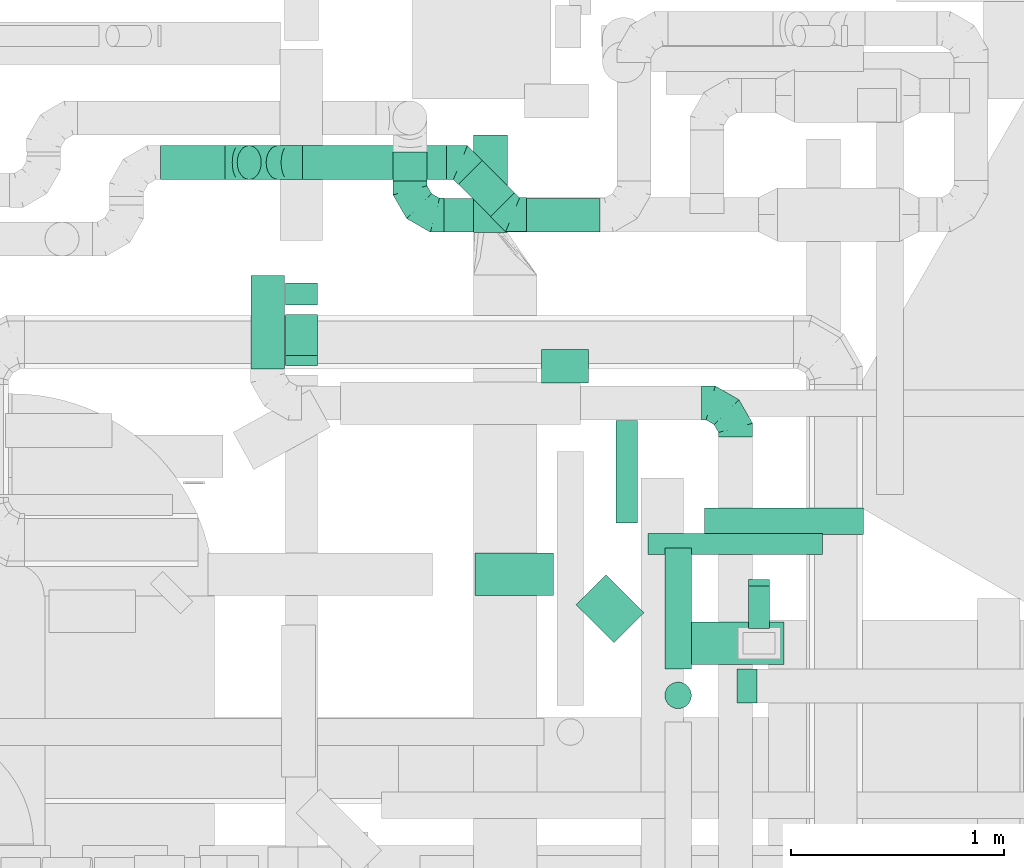
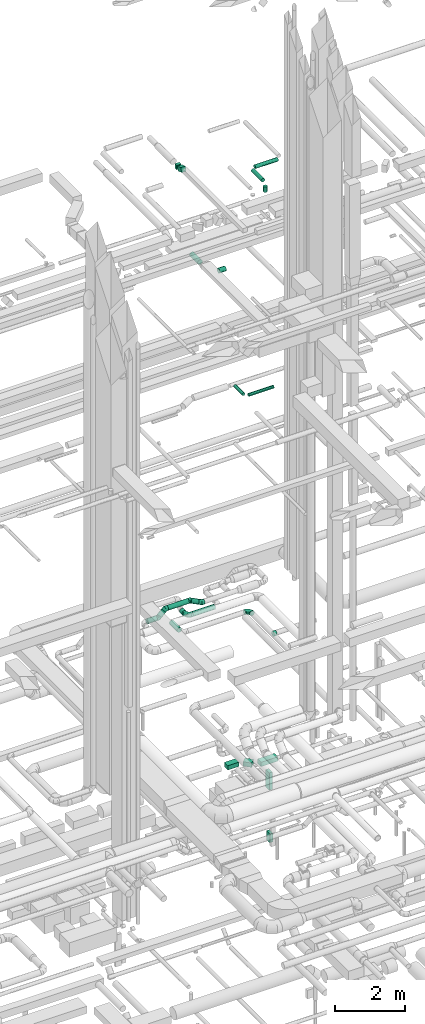
# One storey, part 285 of 337: 21 flow segments, 7 flow fittings.
"""IFC2X3 building model written with IfcOpenShell, lengths in millimetres."""

from ifc_helpers import new_model, entity, si_unit, converted_unit, derived_unit, direction, frame, frame_2d, origin, origin_2d_with_axis, place, context, subcontext, project, spatial, rectangle, circle, extrude, faceted_brep, source, transform, mapped, material, type_object, type_shapes, element, save


model = new_model("IFC2X3")

# Units and contexts
model_context = context("Model", 3, precision=0.01, world=origin(), true_north=direction((6.12303176911189e-17, 1.0)))
body_context = subcontext(model_context, "Body", "Model", "MODEL_VIEW")
ifc_project = project(units=[si_unit("LENGTHUNIT", "METRE", prefix="MILLI"), si_unit("AREAUNIT", "SQUARE_METRE"), si_unit("VOLUMEUNIT", "CUBIC_METRE"), converted_unit("PLANEANGLEUNIT", "DEGREE", entity("IfcRatioMeasure", 0.0174532925199433), si_unit("PLANEANGLEUNIT", "RADIAN"), dimensions=[0, 0, 0, 0, 0, 0, 0]), si_unit("MASSUNIT", "GRAM", prefix="KILO"), derived_unit("MASSDENSITYUNIT", [(si_unit("MASSUNIT", "GRAM", prefix="KILO"), 1), (si_unit("LENGTHUNIT", "METRE"), -3)]), derived_unit("MOMENTOFINERTIAUNIT", [(si_unit("LENGTHUNIT", "METRE"), 4)]), si_unit("TIMEUNIT", "SECOND"), si_unit("FREQUENCYUNIT", "HERTZ"), si_unit("THERMODYNAMICTEMPERATUREUNIT", "DEGREE_CELSIUS"), derived_unit("THERMALTRANSMITTANCEUNIT", [(si_unit("MASSUNIT", "GRAM", prefix="KILO"), 1), (si_unit("THERMODYNAMICTEMPERATUREUNIT", "KELVIN"), -1), (si_unit("TIMEUNIT", "SECOND"), -3)]), derived_unit("VOLUMETRICFLOWRATEUNIT", [(si_unit("LENGTHUNIT", "METRE"), 3), (si_unit("TIMEUNIT", "SECOND"), -1)]), derived_unit("MASSFLOWRATEUNIT", [(si_unit("MASSUNIT", "GRAM", prefix="KILO"), 1), (si_unit("TIMEUNIT", "SECOND"), -1)]), derived_unit("ROTATIONALFREQUENCYUNIT", [(si_unit("TIMEUNIT", "SECOND"), -1)]), si_unit("ELECTRICCURRENTUNIT", "AMPERE"), si_unit("ELECTRICVOLTAGEUNIT", "VOLT"), si_unit("POWERUNIT", "WATT"), si_unit("FORCEUNIT", "NEWTON", prefix="KILO"), si_unit("ILLUMINANCEUNIT", "LUX"), si_unit("LUMINOUSFLUXUNIT", "LUMEN"), si_unit("LUMINOUSINTENSITYUNIT", "CANDELA"), derived_unit("USERDEFINED", [(si_unit("MASSUNIT", "GRAM", prefix="KILO"), -1), (si_unit("LENGTHUNIT", "METRE"), -2), (si_unit("TIMEUNIT", "SECOND"), 3), (si_unit("LUMINOUSFLUXUNIT", "LUMEN"), 1)]), derived_unit("LINEARVELOCITYUNIT", [(si_unit("LENGTHUNIT", "METRE"), 1), (si_unit("TIMEUNIT", "SECOND"), -1)]), si_unit("PRESSUREUNIT", "PASCAL"), derived_unit("USERDEFINED", [(si_unit("LENGTHUNIT", "METRE"), -2), (si_unit("MASSUNIT", "GRAM", prefix="KILO"), 1), (si_unit("TIMEUNIT", "SECOND"), -2)]), derived_unit("LINEARFORCEUNIT", [(si_unit("MASSUNIT", "GRAM", prefix="KILO"), 1), (si_unit("LENGTHUNIT", "METRE"), 1), (si_unit("TIMEUNIT", "SECOND"), -2), (si_unit("LENGTHUNIT", "METRE"), -1)]), derived_unit("PLANARFORCEUNIT", [(si_unit("MASSUNIT", "GRAM", prefix="KILO"), 1), (si_unit("LENGTHUNIT", "METRE"), 1), (si_unit("TIMEUNIT", "SECOND"), -2), (si_unit("LENGTHUNIT", "METRE"), -2)])], contexts=[model_context])

# Site, building, storey
site_placement = place(None, origin())
site = spatial("IfcSite", under=ifc_project, at=site_placement, CompositionType="ELEMENT")
building_placement = place(site_placement, origin())
building = spatial("IfcBuilding", under=site, at=building_placement, CompositionType="ELEMENT")
storey_placement = place(building_placement, origin())
storey = spatial("IfcBuildingStorey", under=building, at=storey_placement, CompositionType="ELEMENT", Elevation=0.0)

# Flow segments
duct_segment_type_1 = type_object("IfcDuctSegmentType", PredefinedType="NOTDEFINED")
flow_segment_1_placement = place(storey_placement, frame((51691.08, 16773.88, -1175.0)))
element("IfcFlowSegment", 1, at=flow_segment_1_placement, inside=storey, type_object=duct_segment_type_1, context=body_context, shape_type="SweptSolid", body=[
    extrude(rectangle(XDim=368.792499999528, YDim=200.0, at=origin_2d_with_axis()), frame((184.4, 100.0, 0.0)), (0.0, 0.0, 1.0), 150.0),
])
flow_segment_2_placement = place(storey_placement, frame((52165.94, 16551.38, -1175.0)))
element("IfcFlowSegment", 2, at=flow_segment_2_placement, inside=storey, type_object=duct_segment_type_1, context=body_context, shape_type="SweptSolid", body=[
    extrude(rectangle(XDim=252.528762761456, YDim=200.000000000004, at=origin_2d_with_axis()), frame((159.99, 159.99, 0.0), z_axis=(0.0, 0.0, 1.0), x_axis=(0.70710678118653, -0.707106781186565, 0.0)), (0.0, 0.0, 1.0), 150.0),
])
flow_segment_3_placement = place(storey_placement, frame((52591.99, 16448.87, -1175.0)))
element("IfcFlowSegment", 3, at=flow_segment_3_placement, inside=storey, type_object=duct_segment_type_1, context=body_context, shape_type="SweptSolid", body=[
    extrude(rectangle(XDim=553.166326049516, YDim=200.0, at=origin_2d_with_axis()), frame((276.58, 100.0, 0.0)), (0.0, 0.0, 1.0), 150.0),
])
flow_segment_4_placement = place(storey_placement, frame((52976.91, 16643.87, -2245.0)))
element("IfcFlowSegment", 4, at=flow_segment_4_placement, inside=storey, type_object=duct_segment_type_1, context=body_context, shape_type="SweptSolid", body=[
    extrude(rectangle(XDim=204.999999999969, YDim=100.000000000003, at=origin_2d_with_axis()), frame((50.0, 102.5, 0.0), z_axis=(0.0, 0.0, 1.0), x_axis=(0.0, 1.0, 0.0)), (0.0, 0.0, 1.0), 600.0),
])
flow_segment_5_placement = place(storey_placement, frame((52976.91, 16618.87, -4050.0)))
element("IfcFlowSegment", 5, at=flow_segment_5_placement, inside=storey, type_object=duct_segment_type_1, context=body_context, shape_type="SweptSolid", body=[
    extrude(rectangle(XDim=200.000024999863, YDim=100.000000000003, at=origin_2d_with_axis()), frame((50.0, 100.0, 0.0), z_axis=(0.0, 0.0, 1.0), x_axis=(0.0, 1.0, 0.0)), (0.0, 0.0, 1.0), 300.0),
])
flow_segment_6_placement = place(storey_placement, frame((50799.92, 17855.43, 19131.13)))
element("IfcFlowSegment", 6, at=flow_segment_6_placement, inside=storey, type_object=duct_segment_type_1, context=body_context, shape_type="SweptSolid", body=[
    extrude(rectangle(XDim=149.999999999999, YDim=150.000000000001, at=frame_2d((0.0, 0.0), x_axis=(0.0, 1.0))), frame((75.0, 22.81, 133.21), z_axis=(0.0, 0.952613829144615, -0.304182334336554), x_axis=(-1.0, 0.0, 0.0)), (0.0, 0.0, 1.0), 203.041489867537),
])
flow_segment_7_placement = place(storey_placement, frame((50799.92, 18140.11, 19116.91)))
element("IfcFlowSegment", 7, at=flow_segment_7_placement, inside=storey, type_object=duct_segment_type_1, context=body_context, shape_type="SweptSolid", body=[
    extrude(rectangle(XDim=103.740397768013, YDim=150.000000000001, at=origin_2d_with_axis()), frame((75.0, 51.87, 0.0), z_axis=(0.0, 0.0, 1.0), x_axis=(0.0, 1.0, 0.0)), (0.0, 0.0, 1.0), 150.000000000001),
])
duct_segment_type_2 = type_object("IfcDuctSegmentType", PredefinedType="NOTDEFINED")
flow_segment_8_placement = place(storey_placement, frame((52353.24, 17115.6, 11348.4)))
element("IfcFlowSegment", 8, at=flow_segment_8_placement, inside=storey, type_object=duct_segment_type_2, context=body_context, shape_type="SweptSolid", body=[
    extrude(circle(Radius=50.0, at=origin_2d_with_axis()), frame((51.6, 0.0, 51.6), z_axis=(0.0, 1.0, 0.0), x_axis=(-1.0, 0.0, 0.0)), (0.0, 0.0, 1.0), 479.999999999999),
])
flow_segment_9_placement = place(storey_placement, frame((52504.84, 16964.01, 11348.4)))
element("IfcFlowSegment", 9, at=flow_segment_9_placement, inside=storey, type_object=duct_segment_type_2, context=body_context, shape_type="SweptSolid", body=[
    extrude(circle(Radius=50.0, at=origin_2d_with_axis()), frame((0.0, 51.6, 51.6), z_axis=(1.0, 0.0, 0.0), x_axis=(0.0, -1.0, 0.0)), (0.0, 0.0, 1.0), 820.000000000004),
])
flow_segment_10_placement = place(storey_placement, frame((52582.47, 16428.82, 19085.9)))
element("IfcFlowSegment", 10, at=flow_segment_10_placement, inside=storey, type_object=duct_segment_type_2, context=body_context, shape_type="SweptSolid", body=[
    extrude(circle(Radius=62.5, at=origin_2d_with_axis()), frame((64.1, 0.0, 64.1), z_axis=(0.0, 1.0, 0.0), x_axis=(1.0, 0.0, 0.0)), (0.0, 0.0, 1.0), 569.000000000033),
])
flow_segment_11_placement = place(storey_placement, frame((52771.56, 17058.73, 19085.9)))
element("IfcFlowSegment", 11, at=flow_segment_11_placement, inside=storey, type_object=duct_segment_type_2, context=body_context, shape_type="SweptSolid", body=[
    extrude(circle(Radius=62.5, at=origin_2d_with_axis()), frame((0.0, 64.1, 64.1), z_axis=(1.0, 0.0, 0.0), x_axis=(0.0, -1.0, 0.0)), (0.0, 0.0, 1.0), 746.250000000112),
])
flow_segment_12_placement = place(storey_placement, frame((51682.37, 18479.95, 15293.4)))
element("IfcFlowSegment", 12, at=flow_segment_12_placement, inside=storey, type_object=duct_segment_type_2, context=body_context, shape_type="SweptSolid", body=[
    extrude(circle(Radius=80.0, at=origin_2d_with_axis()), frame((81.6, 0.0, 81.6), z_axis=(0.0, 1.0, 0.0), x_axis=(-1.0, 0.0, 0.0)), (0.0, 0.0, 1.0), 460.000000000015),
])
flow_segment_13_placement = place(storey_placement, frame((52003.97, 17770.02, 15293.4)))
element("IfcFlowSegment", 13, at=flow_segment_13_placement, inside=storey, type_object=duct_segment_type_2, context=body_context, shape_type="SweptSolid", body=[
    extrude(circle(Radius=80.0, at=origin_2d_with_axis()), frame((0.0, 81.6, 81.6), z_axis=(1.0, 0.0, 0.0), x_axis=(0.0, -1.0, 0.0)), (0.0, 0.0, 1.0), 219.999999999967),
])
flow_segment_14_placement = place(storey_placement, frame((52582.47, 16239.73, 18845.0)))
element("IfcFlowSegment", 14, at=flow_segment_14_placement, inside=storey, type_object=duct_segment_type_2, context=body_context, shape_type="SweptSolid", body=[
    extrude(circle(Radius=62.5, at=origin_2d_with_axis()), frame((64.1, 64.1, 0.0), z_axis=(0.0, 0.0, 1.0), x_axis=(-1.0, 0.0, 0.0)), (0.0, 0.0, 1.0), 180.000000000052),
])
flow_segment_15_placement = place(storey_placement, frame((51545.84, 18480.02, 3118.4)))
element("IfcFlowSegment", 15, at=flow_segment_15_placement, inside=storey, type_object=duct_segment_type_2, context=body_context, shape_type="SweptSolid", body=[
    extrude(circle(Radius=80.0, at=origin_2d_with_axis()), frame((0.0, 81.6, 81.6), z_axis=(1.0, 0.0, 0.0), x_axis=(0.0, -1.0, 0.0)), (0.0, 0.0, 1.0), 732.500000000007),
])
flow_segment_16_placement = place(storey_placement, frame((51304.24, 18721.61, 3118.4)))
element("IfcFlowSegment", 16, at=flow_segment_16_placement, inside=storey, type_object=duct_segment_type_2, context=body_context, shape_type="SweptSolid", body=[
    extrude(circle(Radius=80.0, at=origin_2d_with_axis()), frame((81.6, 0.0, 81.6), z_axis=(0.0, 1.0, 0.0), x_axis=(1.0, 0.0, 0.0)), (0.0, 0.0, 1.0), 137.500000000034),
])
flow_segment_17_placement = place(storey_placement, frame((51611.62, 18552.81, 3418.4)))
element("IfcFlowSegment", 17, at=flow_segment_17_placement, inside=storey, type_object=duct_segment_type_2, context=body_context, shape_type="SweptSolid", body=[
    extrude(circle(Radius=80.0, at=origin_2d_with_axis()), frame((209.85, 58.16, 81.6), z_axis=(-0.707106781186477, 0.707106781186618, 0.0), x_axis=(0.707106781186618, 0.707106781186477, 0.0)), (0.0, 0.0, 1.0), 214.52272785248),
])
flow_segment_18_placement = place(storey_placement, frame((50212.92, 18727.93, 3188.4)))
element("IfcFlowSegment", 18, at=flow_segment_18_placement, inside=storey, type_object=duct_segment_type_2, context=body_context, shape_type="SweptSolid", body=[
    extrude(circle(Radius=80.0, at=origin_2d_with_axis()), frame((0.0, 81.6, 81.6), z_axis=(1.0, 0.0, 0.0), x_axis=(0.0, 1.0, 0.0)), (0.0, 0.0, 1.0), 303.725830020343),
])
flow_segment_19_placement = place(storey_placement, frame((50879.19, 18727.93, 3418.4)))
element("IfcFlowSegment", 19, at=flow_segment_19_placement, inside=storey, type_object=duct_segment_type_2, context=body_context, shape_type="SweptSolid", body=[
    extrude(circle(Radius=80.0, at=origin_2d_with_axis()), frame((0.0, 81.6, 81.6), z_axis=(1.0, 0.0, 0.0), x_axis=(0.0, 1.0, 0.0)), (0.0, 0.0, 1.0), 677.451660040652),
])
flow_segment_20_placement = place(storey_placement, frame((50571.62, 18727.93, 3258.7)))
element("IfcFlowSegment", 20, at=flow_segment_20_placement, inside=storey, type_object=duct_segment_type_2, context=body_context, shape_type="SweptSolid", body=[
    extrude(circle(Radius=80.0, at=origin_2d_with_axis()), frame((58.16, 81.6, 58.16), z_axis=(0.707106781186543, 0.0, 0.707106781186552), x_axis=(0.0, 1.0, 0.0)), (0.0, 0.0, 1.0), 192.720779386393),
])
flow_segment_21_placement = place(storey_placement, frame((50635.15, 17838.74, 3298.4)))
element("IfcFlowSegment", 21, at=flow_segment_21_placement, inside=storey, type_object=duct_segment_type_2, context=body_context, shape_type="SweptSolid", body=[
    extrude(circle(Radius=80.0, at=origin_2d_with_axis()), frame((81.6, 0.0, 81.6), z_axis=(0.0, 1.0, 0.0), x_axis=(1.0, 0.0, 0.0)), (0.0, 0.0, 1.0), 440.000000000006),
])

# Flow fittings
ifc_material = material()
duct_fitting_type_1 = type_object("IfcDuctFittingType", PredefinedType="NOTDEFINED", material=ifc_material)
shared_shape_1 = source(origin(), body_context, "Body", "Brep", [
    faceted_brep([(-160.0, 0.0, -80.0), (-160.0, -20.71, -77.27), (-160.0, -40.0, -69.28), (-160.0, -56.57, -56.57), (-160.0, -69.28, -40.0), (-160.0, -77.27, -20.71), (-160.0, -80.0, 0.0), (-160.0, -77.27, 20.71), (-160.0, -69.28, 40.0), (-160.0, -56.57, 56.57), (-160.0, -40.0, 69.28), (-160.0, -20.71, 77.27), (-160.0, 0.0, 80.0), (-160.0, 20.71, 77.27), (-160.0, 40.0, 69.28), (-160.0, 56.57, 56.57), (-160.0, 69.28, 40.0), (-160.0, 77.27, 20.71), (-160.0, 80.0, 0.0), (-160.0, 77.27, -20.71), (-160.0, 69.28, -40.0), (-160.0, 56.57, -56.57), (-160.0, 40.0, -69.28), (-160.0, 20.71, -77.27), (-122.68, 20.71, 77.27), (-127.85, 40.0, 69.28), (-117.13, 0.0, 80.0), (-132.29, 56.57, 56.57), (-137.83, 77.27, 20.71), (-138.56, 80.0, 0.0), (-135.69, 69.28, 40.0), (-135.69, 69.28, -40.0), (-132.29, 56.57, -56.57), (-137.83, 77.27, -20.71), (-122.68, 20.71, -77.27), (-117.13, 0.0, -80.0), (-127.85, 40.0, -69.28), (-111.58, -20.71, -77.27), (-106.41, -40.0, -69.28), (-101.97, -56.57, -56.57), (-98.56, -69.28, -40.0), (-96.42, -77.27, -20.71), (-95.69, -80.0, 0.0), (-96.42, -77.27, 20.71), (-98.56, -69.28, 40.0), (-101.97, -56.57, 56.57), (-106.41, -40.0, 69.28), (-111.58, -20.71, 77.27), (-58.03, 58.03, 77.27), (-72.15, 72.15, 69.28), (-42.87, 42.87, 80.0), (-84.28, 84.28, 56.57), (-93.59, 93.59, 40.0), (-99.44, 99.44, 20.71), (-101.44, 101.44, 0.0), (-99.44, 99.44, -20.71), (-93.59, 93.59, -40.0), (-84.28, 84.28, -56.57), (-58.03, 58.03, -77.27), (-42.87, 42.87, -80.0), (-72.15, 72.15, -69.28), (-27.71, 27.71, -77.27), (-13.59, 13.59, -69.28), (-1.46, 1.46, -56.57), (7.85, -7.85, -40.0), (13.7, -13.7, -20.71), (15.69, -15.69, 0.0), (13.7, -13.7, 20.71), (7.85, -7.85, 40.0), (-1.46, 1.46, 56.57), (-13.59, 13.59, 69.28), (-27.71, 27.71, 77.27), (-20.71, 122.68, 77.27), (-40.0, 127.85, 69.28), (0.0, 117.13, 80.0), (-56.57, 132.29, 56.57), (-69.28, 135.69, 40.0), (-77.27, 137.83, 20.71), (-80.0, 138.56, 0.0), (-77.27, 137.83, -20.71), (-69.28, 135.69, -40.0), (-56.57, 132.29, -56.57), (-20.71, 122.68, -77.27), (0.0, 117.13, -80.0), (-40.0, 127.85, -69.28), (20.71, 111.58, -77.27), (40.0, 106.41, -69.28), (56.57, 101.97, -56.57), (69.28, 98.56, -40.0), (77.27, 96.42, -20.71), (80.0, 95.69, 0.0), (77.27, 96.42, 20.71), (69.28, 98.56, 40.0), (56.57, 101.97, 56.57), (40.0, 106.41, 69.28), (20.71, 111.58, 77.27), (-20.71, 160.0, -77.27), (-40.0, 160.0, -69.28), (-56.57, 160.0, -56.57), (-69.28, 160.0, -40.0), (-77.27, 160.0, -20.71), (-80.0, 160.0, 0.0), (-77.27, 160.0, 20.71), (-69.28, 160.0, 40.0), (-56.57, 160.0, 56.57), (-40.0, 160.0, 69.28), (-20.71, 160.0, 77.27), (0.0, 160.0, 80.0), (20.71, 160.0, 77.27), (40.0, 160.0, 69.28), (56.57, 160.0, 56.57), (69.28, 160.0, 40.0), (77.27, 160.0, 20.71), (80.0, 160.0, 0.0), (77.27, 160.0, -20.71), (69.28, 160.0, -40.0), (56.57, 160.0, -56.57), (40.0, 160.0, -69.28), (20.71, 160.0, -77.27), (0.0, 160.0, -80.0)], [[[0, 1, 2, 3, 4, 5, 6, 7, 8, 9, 10, 11, 12, 13, 14, 15, 16, 17, 18, 19, 20, 21, 22, 23]], [[24, 25, 14, 13]], [[26, 24, 13, 12]], [[14, 25, 27, 15]], [[28, 29, 18, 17]], [[30, 28, 17, 16]], [[15, 27, 30, 16]], [[20, 31, 32, 21]], [[33, 31, 20, 19]], [[18, 29, 33, 19]], [[34, 35, 0, 23]], [[36, 34, 23, 22]], [[32, 36, 22, 21]], [[1, 0, 35, 37]], [[2, 1, 37, 38]], [[3, 2, 38, 39]], [[5, 4, 40, 41]], [[6, 5, 41, 42]], [[39, 40, 4, 3]], [[6, 42, 43, 7]], [[7, 43, 44, 8]], [[8, 44, 45, 9]], [[9, 45, 46, 10]], [[10, 46, 47, 11]], [[26, 12, 11, 47]], [[48, 49, 25, 24]], [[50, 48, 24, 26]], [[27, 25, 49, 51]], [[52, 53, 28, 30]], [[51, 52, 30, 27]], [[29, 28, 53, 54]], [[55, 56, 31, 33]], [[54, 55, 33, 29]], [[32, 31, 56, 57]], [[58, 59, 35, 34]], [[60, 58, 34, 36]], [[57, 60, 36, 32]], [[37, 35, 59, 61]], [[38, 37, 61, 62]], [[39, 38, 62, 63]], [[41, 40, 64, 65]], [[42, 41, 65, 66]], [[63, 64, 40, 39]], [[43, 42, 66, 67]], [[44, 43, 67, 68]], [[68, 69, 45, 44]], [[46, 45, 69, 70]], [[47, 46, 70, 71]], [[26, 47, 71, 50]], [[72, 73, 49, 48]], [[74, 72, 48, 50]], [[51, 49, 73, 75]], [[76, 77, 53, 52]], [[75, 76, 52, 51]], [[54, 53, 77, 78]], [[79, 80, 56, 55]], [[78, 79, 55, 54]], [[57, 56, 80, 81]], [[82, 83, 59, 58]], [[84, 82, 58, 60]], [[81, 84, 60, 57]], [[61, 59, 83, 85]], [[62, 61, 85, 86]], [[63, 62, 86, 87]], [[65, 64, 88, 89]], [[66, 65, 89, 90]], [[87, 88, 64, 63]], [[67, 66, 90, 91]], [[68, 67, 91, 92]], [[92, 93, 69, 68]], [[70, 69, 93, 94]], [[71, 70, 94, 95]], [[50, 71, 95, 74]], [[96, 97, 98, 99, 100, 101, 102, 103, 104, 105, 106, 107, 108, 109, 110, 111, 112, 113, 114, 115, 116, 117, 118, 119]], [[72, 74, 107, 106]], [[73, 72, 106, 105]], [[75, 73, 105, 104]], [[77, 76, 103, 102]], [[78, 77, 102, 101]], [[75, 104, 103, 76]], [[78, 101, 100, 79]], [[79, 100, 99, 80]], [[80, 99, 98, 81]], [[84, 97, 96, 82]], [[82, 96, 119, 83]], [[84, 81, 98, 97]], [[118, 117, 86, 85]], [[119, 118, 85, 83]], [[116, 87, 86, 117]], [[88, 115, 114, 89]], [[89, 114, 113, 90]], [[115, 88, 87, 116]], [[112, 111, 92, 91]], [[113, 112, 91, 90]], [[111, 110, 93, 92]], [[95, 94, 109, 108]], [[74, 95, 108, 107]], [[110, 109, 94, 93]]]),
])
type_shapes(duct_fitting_type_1, [shared_shape_1])
for number, where, z_axis, x_axis in (
    (22, (51385.84, 18561.61, 3200.0), (0.0, 0.0, 1.0), (0.0, -1.0, 0.0)),
    (23, (52916.74, 17678.74, 3380.0), (0.0, 0.0, 1.0), (0.0, 1.0, 0.0)),
):
    element("IfcFlowFitting", number, at=place(storey_placement, frame(where, z_axis=z_axis, x_axis=x_axis)), inside=storey, type_object=duct_fitting_type_1, material=ifc_material, context=body_context, shape_type="MappedRepresentation", body=[
        mapped(shared_shape_1, transform((0.0, 0.0, 0.0), scale=1.0)),
    ])
duct_fitting_type_2 = type_object("IfcDuctFittingType", PredefinedType="NOTDEFINED", material=ifc_material)
shared_shape_2 = source(origin(), body_context, "Body", "Brep", [
    faceted_brep([(-66.27, 0.0, -80.0), (-66.27, -20.71, -77.27), (-66.27, -40.0, -69.28), (-66.27, -56.57, -56.57), (-66.27, -69.28, -40.0), (-66.27, -77.27, -20.71), (-66.27, -80.0, 0.0), (-66.27, -77.27, 20.71), (-66.27, -69.28, 40.0), (-66.27, -56.57, 56.57), (-66.27, -40.0, 69.28), (-66.27, -20.71, 77.27), (-66.27, 0.0, 80.0), (-66.27, 20.71, 77.27), (-66.27, 40.0, 69.28), (-66.27, 56.57, 56.57), (-66.27, 69.28, 40.0), (-66.27, 77.27, 20.71), (-66.27, 80.0, 0.0), (-66.27, 77.27, -20.71), (-66.27, 69.28, -40.0), (-66.27, 56.57, -56.57), (-66.27, 40.0, -69.28), (-66.27, 20.71, -77.27), (-8.58, 20.71, 77.27), (-16.57, 40.0, 69.28), (0.0, 0.0, 80.0), (-23.43, 56.57, 56.57), (-28.7, 69.28, 40.0), (-32.01, 77.27, 20.71), (-33.14, 80.0, 0.0), (-32.01, 77.27, -20.71), (-28.7, 69.28, -40.0), (-23.43, 56.57, -56.57), (-8.58, 20.71, -77.27), (0.0, 0.0, -80.0), (-16.57, 40.0, -69.28), (8.58, -20.71, -77.27), (16.57, -40.0, -69.28), (23.43, -56.57, -56.57), (28.7, -69.28, -40.0), (32.01, -77.27, -20.71), (33.14, -80.0, 0.0), (32.01, -77.27, 20.71), (28.7, -69.28, 40.0), (23.43, -56.57, 56.57), (16.57, -40.0, 69.28), (8.58, -20.71, 77.27), (46.86, 46.86, 80.0), (32.22, 61.5, 77.27), (18.58, 75.15, 69.28), (6.86, 86.86, 56.57), (-2.13, 95.85, 40.0), (-7.78, 101.5, 20.71), (-9.71, 103.43, 0.0), (-7.78, 101.5, -20.71), (-2.13, 95.85, -40.0), (6.86, 86.86, -56.57), (18.58, 75.15, -69.28), (32.22, 61.5, -77.27), (46.86, 46.86, -80.0), (61.5, 32.22, -77.27), (75.15, 18.58, -69.28), (86.86, 6.86, -56.57), (95.85, -2.13, -40.0), (101.5, -7.78, -20.71), (103.43, -9.71, 0.0), (101.5, -7.78, 20.71), (95.85, -2.13, 40.0), (86.86, 6.86, 56.57), (75.15, 18.58, 69.28), (61.5, 32.22, 77.27)], [[[0, 1, 2, 3, 4, 5, 6, 7, 8, 9, 10, 11, 12, 13, 14, 15, 16, 17, 18, 19, 20, 21, 22, 23]], [[24, 25, 14, 13]], [[26, 24, 13, 12]], [[14, 25, 27, 15]], [[28, 29, 17, 16]], [[28, 16, 15, 27]], [[30, 18, 17, 29]], [[31, 32, 20, 19]], [[30, 31, 19, 18]], [[32, 33, 21, 20]], [[34, 35, 0, 23]], [[36, 34, 23, 22]], [[33, 36, 22, 21]], [[1, 0, 35, 37]], [[2, 1, 37, 38]], [[38, 39, 3, 2]], [[5, 4, 40, 41]], [[6, 5, 41, 42]], [[39, 40, 4, 3]], [[6, 42, 43, 7]], [[7, 43, 44, 8]], [[8, 44, 45, 9]], [[9, 45, 46, 10]], [[10, 46, 47, 11]], [[26, 12, 11, 47]], [[24, 26, 48, 49]], [[25, 24, 49, 50]], [[27, 25, 50, 51]], [[29, 28, 52, 53]], [[30, 29, 53, 54]], [[51, 52, 28, 27]], [[30, 54, 55, 31]], [[31, 55, 56, 32]], [[57, 33, 32, 56]], [[36, 58, 59, 34]], [[34, 59, 60, 35]], [[58, 36, 33, 57]], [[35, 60, 61, 37]], [[37, 61, 62, 38]], [[63, 39, 38, 62]], [[40, 64, 65, 41]], [[41, 65, 66, 42]], [[64, 40, 39, 63]], [[43, 42, 66, 67]], [[44, 43, 67, 68]], [[68, 69, 45, 44]], [[47, 46, 70, 71]], [[26, 47, 71, 48]], [[69, 70, 46, 45]], [[59, 58, 57, 56, 55, 54, 53, 52, 51, 50, 49, 48, 71, 70, 69, 68, 67, 66, 65, 64, 63, 62, 61, 60]]]),
])
type_shapes(duct_fitting_type_2, [shared_shape_2])
for number, where, z_axis, x_axis in (
    (24, (51868.34, 18564.11, 3500.0), (0.0, 0.0, 1.0), (0.707106781186541, -0.707106781186554, 0.0)),
    (25, (51622.92, 18809.53, 3500.0), (0.0, 0.0, 1.0), (-0.707106781186512, 0.707106781186583, 0.0)),
    (26, (50812.92, 18809.53, 3500.0), (0.0, -1.0, 0.0), (-1.0, 0.0, 0.0)),
    (27, (50582.92, 18809.53, 3270.0), (0.0, 1.0, 0.0), (-0.707106781186481, 0.0, -0.707106781186614)),
):
    element("IfcFlowFitting", number, at=place(storey_placement, frame(where, z_axis=z_axis, x_axis=x_axis)), inside=storey, type_object=duct_fitting_type_2, material=ifc_material, context=body_context, shape_type="MappedRepresentation", body=[
        mapped(shared_shape_2, transform((0.0, 0.0, 0.0), scale=1.0)),
    ])
duct_fitting_type_3 = type_object("IfcDuctFittingType", PredefinedType="NOTDEFINED", material=ifc_material)
shared_shape_3 = source(origin(), body_context, "Body", "Brep", [
    faceted_brep([(20.0, 20.71, -77.27), (20.0, 40.0, -69.28), (20.0, 56.57, -56.57), (20.0, 69.28, -40.0), (20.0, 77.27, -20.71), (20.0, 80.0, 0.0), (20.0, 77.27, 20.71), (20.0, 69.28, 40.0), (20.0, 56.57, 56.57), (20.0, 40.0, 69.28), (20.0, 20.71, 77.27), (20.0, 0.0, 80.0), (20.0, -20.71, 77.27), (20.0, -40.0, 69.28), (20.0, -56.57, 56.57), (20.0, -69.28, 40.0), (20.0, -77.27, 20.71), (20.0, -80.0, 0.0), (20.0, -77.27, -20.71), (20.0, -69.28, -40.0), (20.0, -56.57, -56.57), (20.0, -40.0, -69.28), (20.0, -20.71, -77.27), (20.0, 0.0, -80.0), (0.0, 0.0, 80.0), (0.0, 20.71, 77.27), (-73.9, 20.71, 77.27), (-73.9, 0.0, 80.0), (0.0, 40.0, 69.28), (-73.9, 40.0, 69.28), (0.0, 56.57, 56.57), (-73.9, 56.57, 56.57), (0.0, 69.28, 40.0), (0.0, 77.27, 20.71), (-73.9, 77.27, 20.71), (-73.9, 69.28, 40.0), (0.0, 80.0, 0.0), (-73.9, 80.0, 0.0), (0.0, 77.27, -20.71), (-73.9, 77.27, -20.71), (0.0, 69.28, -40.0), (-73.9, 69.28, -40.0), (0.0, 56.57, -56.57), (-73.9, 56.57, -56.57), (0.0, 40.0, -69.28), (0.0, 20.71, -77.27), (-73.9, 20.71, -77.27), (-73.9, 40.0, -69.28), (0.0, 0.0, -80.0), (-73.9, 0.0, -80.0), (0.0, -20.71, -77.27), (-73.9, -20.71, -77.27), (0.0, -40.0, -69.28), (-73.9, -40.0, -69.28), (0.0, -56.57, -56.57), (-73.9, -56.57, -56.57), (0.0, -69.28, -40.0), (0.0, -77.27, -20.71), (-73.9, -77.27, -20.71), (-73.9, -69.28, -40.0), (0.0, -80.0, 0.0), (-73.9, -80.0, 0.0), (0.0, -77.27, 20.71), (-73.9, -77.27, 20.71), (0.0, -69.28, 40.0), (-73.9, -69.28, 40.0), (0.0, -56.57, 56.57), (-73.9, -56.57, 56.57), (0.0, -40.0, 69.28), (0.0, -20.71, 77.27), (-73.9, -20.71, 77.27), (-73.9, -40.0, 69.28)], [[[0, 1, 2, 3, 4, 5, 6, 7, 8, 9, 10, 11, 12, 13, 14, 15, 16, 17, 18, 19, 20, 21, 22, 23]], [[24, 11, 10, 25, 26, 27]], [[25, 10, 9, 28, 29, 26]], [[28, 9, 8, 30, 31, 29]], [[32, 7, 6, 33, 34, 35]], [[33, 6, 5, 36, 37, 34]], [[30, 8, 7, 32, 35, 31]], [[36, 5, 4, 38, 39, 37]], [[38, 4, 3, 40, 41, 39]], [[40, 3, 2, 42, 43, 41]], [[44, 1, 0, 45, 46, 47]], [[45, 0, 23, 48, 49, 46]], [[42, 2, 1, 44, 47, 43]], [[48, 23, 22, 50, 51, 49]], [[50, 22, 21, 52, 53, 51]], [[52, 21, 20, 54, 55, 53]], [[56, 19, 18, 57, 58, 59]], [[57, 18, 17, 60, 61, 58]], [[54, 20, 19, 56, 59, 55]], [[60, 17, 16, 62, 63, 61]], [[62, 16, 15, 64, 65, 63]], [[64, 15, 14, 66, 67, 65]], [[68, 13, 12, 69, 70, 71]], [[69, 12, 11, 24, 27, 70]], [[66, 14, 13, 68, 71, 67]], [[49, 51, 53, 55, 59, 58, 61, 63, 65, 67, 71, 70, 27, 26, 29, 31, 35, 34, 37, 39, 41, 43, 47, 46]]]),
])
type_shapes(duct_fitting_type_3, [shared_shape_3])
flow_fitting_placement = place(storey_placement, frame((52996.74, 16348.03, 3380.0), z_axis=(0.0, 0.0, -1.0), x_axis=(1.0, 0.0, 0.0)))
element("IfcFlowFitting", 28, at=flow_fitting_placement, inside=storey, type_object=duct_fitting_type_3, material=ifc_material, context=body_context, shape_type="MappedRepresentation", body=[
    mapped(shared_shape_3, transform((0.0, 0.0, 0.0), scale=1.0)),
])

save(model, "model.ifc")
